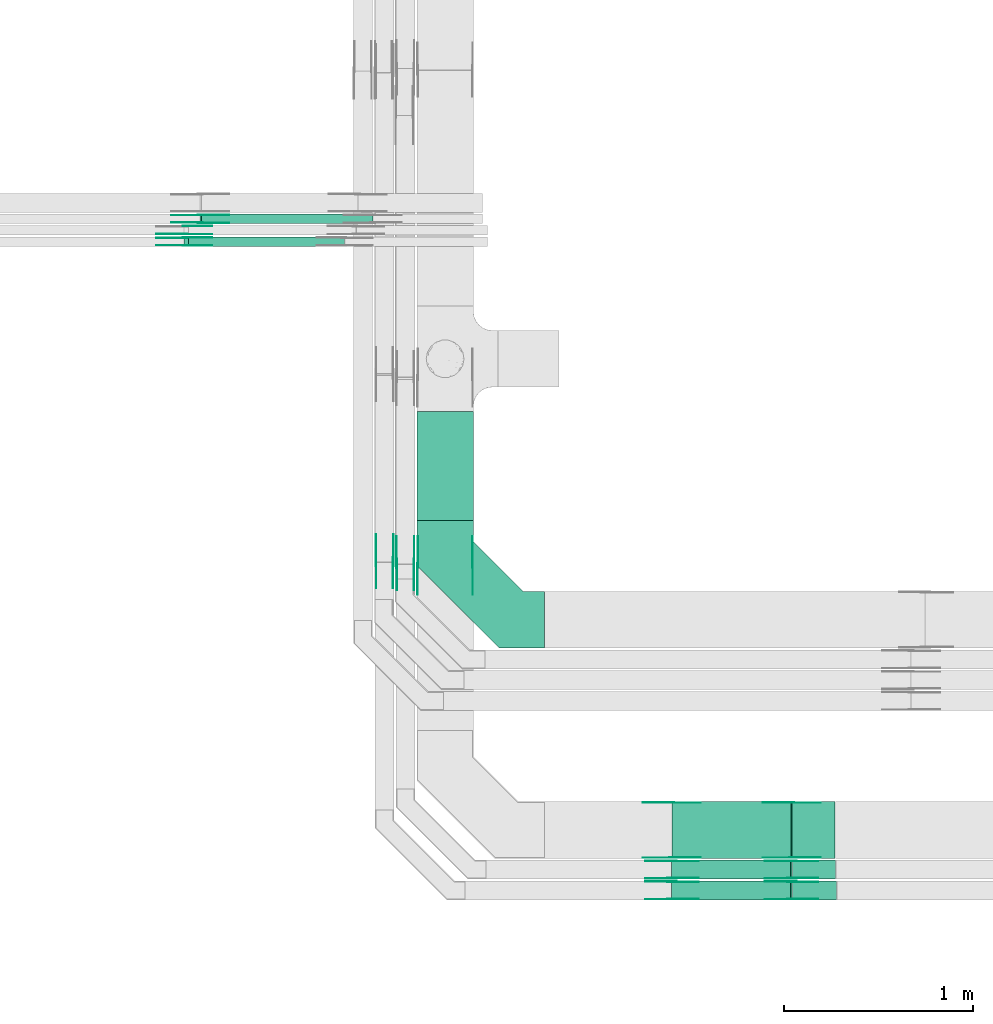
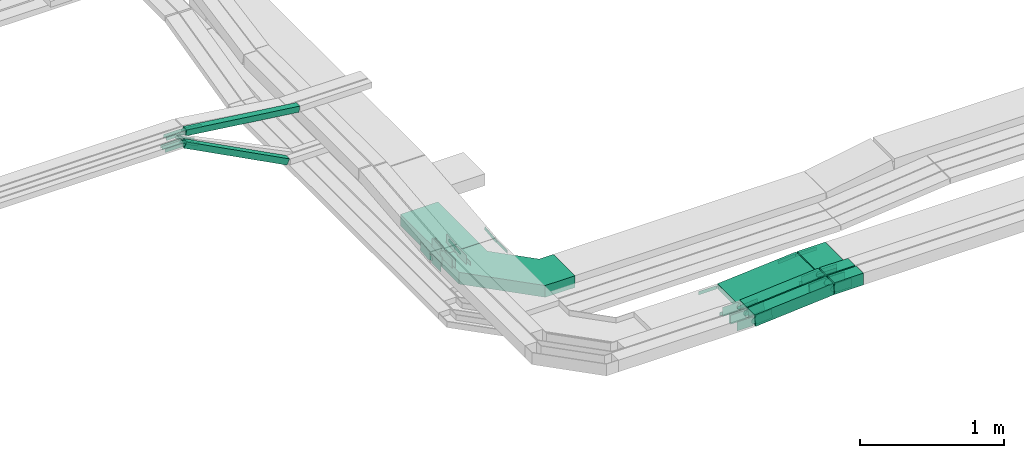
# One storey, part 5 of 32: 48 flow fittings, 9 flow segments.
"""IFC2X3 building model written with IfcOpenShell, lengths in millimetres."""

from ifc_helpers import new_model, entity, si_unit, converted_unit, derived_unit, direction, frame, frame_2d, origin, origin_2d_with_axis, place, context, subcontext, project, spatial, polyline, circle_curve, parameter, trimmed, segment, composite_curve, rectangle, outline, extrude, source, transform, mapped, material, type_object, type_shapes, element, save


model = new_model("IFC2X3")

# Units and contexts
model_context = context("Model", 3, precision=0.01, world=origin(), true_north=direction((6.12303176911189e-17, 1.0)))
body_context = subcontext(model_context, "Body", "Model", "MODEL_VIEW")
ifc_project = project(units=[si_unit("LENGTHUNIT", "METRE", prefix="MILLI"), si_unit("AREAUNIT", "SQUARE_METRE"), si_unit("VOLUMEUNIT", "CUBIC_METRE"), converted_unit("PLANEANGLEUNIT", "DEGREE", entity("IfcRatioMeasure", 0.0174532925199433), si_unit("PLANEANGLEUNIT", "RADIAN"), dimensions=[0, 0, 0, 0, 0, 0, 0]), si_unit("MASSUNIT", "GRAM", prefix="KILO"), derived_unit("MASSDENSITYUNIT", [(si_unit("MASSUNIT", "GRAM", prefix="KILO"), 1), (si_unit("LENGTHUNIT", "METRE"), -3)]), derived_unit("MOMENTOFINERTIAUNIT", [(si_unit("LENGTHUNIT", "METRE"), 4)]), si_unit("TIMEUNIT", "SECOND"), si_unit("FREQUENCYUNIT", "HERTZ"), si_unit("THERMODYNAMICTEMPERATUREUNIT", "DEGREE_CELSIUS"), derived_unit("THERMALTRANSMITTANCEUNIT", [(si_unit("MASSUNIT", "GRAM", prefix="KILO"), 1), (si_unit("THERMODYNAMICTEMPERATUREUNIT", "KELVIN"), -1), (si_unit("TIMEUNIT", "SECOND"), -3)]), derived_unit("VOLUMETRICFLOWRATEUNIT", [(si_unit("LENGTHUNIT", "METRE"), 3), (si_unit("TIMEUNIT", "SECOND"), -1)]), derived_unit("MASSFLOWRATEUNIT", [(si_unit("MASSUNIT", "GRAM", prefix="KILO"), 1), (si_unit("TIMEUNIT", "SECOND"), -1)]), derived_unit("ROTATIONALFREQUENCYUNIT", [(si_unit("TIMEUNIT", "SECOND"), -1)]), si_unit("ELECTRICCURRENTUNIT", "AMPERE"), si_unit("ELECTRICVOLTAGEUNIT", "VOLT"), si_unit("POWERUNIT", "WATT"), si_unit("FORCEUNIT", "NEWTON", prefix="KILO"), si_unit("ILLUMINANCEUNIT", "LUX"), si_unit("LUMINOUSFLUXUNIT", "LUMEN"), si_unit("LUMINOUSINTENSITYUNIT", "CANDELA"), derived_unit("USERDEFINED", [(si_unit("MASSUNIT", "GRAM", prefix="KILO"), -1), (si_unit("LENGTHUNIT", "METRE"), -2), (si_unit("TIMEUNIT", "SECOND"), 3), (si_unit("LUMINOUSFLUXUNIT", "LUMEN"), 1)]), derived_unit("LINEARVELOCITYUNIT", [(si_unit("LENGTHUNIT", "METRE"), 1), (si_unit("TIMEUNIT", "SECOND"), -1)]), si_unit("PRESSUREUNIT", "PASCAL"), derived_unit("USERDEFINED", [(si_unit("LENGTHUNIT", "METRE"), -2), (si_unit("MASSUNIT", "GRAM", prefix="KILO"), 1), (si_unit("TIMEUNIT", "SECOND"), -2)]), derived_unit("LINEARFORCEUNIT", [(si_unit("MASSUNIT", "GRAM", prefix="KILO"), 1), (si_unit("LENGTHUNIT", "METRE"), 1), (si_unit("TIMEUNIT", "SECOND"), -2), (si_unit("LENGTHUNIT", "METRE"), -1)]), derived_unit("PLANARFORCEUNIT", [(si_unit("MASSUNIT", "GRAM", prefix="KILO"), 1), (si_unit("LENGTHUNIT", "METRE"), 1), (si_unit("TIMEUNIT", "SECOND"), -2), (si_unit("LENGTHUNIT", "METRE"), -2)])], contexts=[model_context])

# Site, building, storey
site_placement = place(None, origin())
site = spatial("IfcSite", under=ifc_project, at=site_placement, CompositionType="ELEMENT")
building_placement = place(site_placement, origin())
building = spatial("IfcBuilding", under=site, at=building_placement, CompositionType="ELEMENT")
storey_placement = place(building_placement, frame((0.0, 0.0, 8100.0)))
storey = spatial("IfcBuildingStorey", under=building, at=storey_placement, CompositionType="ELEMENT", Elevation=8100.0)

# Flow segments
cable_carrier_segment_type = type_object("IfcCableCarrierSegmentType", PredefinedType="CABLETRAYSEGMENT")
flow_segment_1_placement = place(storey_placement, frame((18246.05, 10521.0, 2500.0)))
element("IfcFlowSegment", 1, at=flow_segment_1_placement, inside=storey, type_object=cable_carrier_segment_type, context=body_context, shape_type="SweptSolid", body=[
    extrude(rectangle(XDim=575.248008213486, YDim=300.000000000001, at=origin_2d_with_axis()), frame((150.0, 287.62, 0.0), z_axis=(0.0, 0.0, 1.0), x_axis=(0.0, -1.0, 0.0)), (0.0, 0.0, 1.0), 99.9999999999989),
])
flow_segment_2_placement = place(storey_placement, frame((19596.22, 8732.05, 2740.26)))
element("IfcFlowSegment", 2, at=flow_segment_2_placement, inside=storey, type_object=cable_carrier_segment_type, context=body_context, shape_type="SweptSolid", body=[
    extrude(rectangle(XDim=50.0000000000006, YDim=299.999999999999, at=frame_2d((0.0, 0.0), x_axis=(0.0, 1.0))), frame((1.96, 150.0, 24.92), z_axis=(0.996914404286907, 0.0, 0.0784963089914518), x_axis=(0.0, 1.0, 0.0)), (0.0, 0.0, 1.0), 632.69257167876),
])
flow_segment_3_placement = place(storey_placement, frame((19595.24, 8622.45, 2739.94)))
element("IfcFlowSegment", 3, at=flow_segment_3_placement, inside=storey, type_object=cable_carrier_segment_type, context=body_context, shape_type="SweptSolid", body=[
    extrude(rectangle(XDim=99.9999999999994, YDim=100.000000000001, at=frame_2d((0.0, 0.0), x_axis=(0.0, 1.0))), frame((3.94, 50.0, 49.84), z_axis=(0.996898073188744, 0.0, 0.0787034413006861), x_axis=(0.0, 1.0, 0.0)), (0.0, 0.0, 1.0), 630.726472303646),
])
flow_segment_4_placement = place(storey_placement, frame((19595.29, 8512.45, 2739.72)))
element("IfcFlowSegment", 4, at=flow_segment_4_placement, inside=storey, type_object=cable_carrier_segment_type, context=body_context, shape_type="SweptSolid", body=[
    extrude(rectangle(XDim=99.9999999999991, YDim=99.9999999999989, at=frame_2d((0.0, 0.0), x_axis=(0.0, 1.0))), frame((3.92, 50.0, 49.85), z_axis=(0.996914404286927, 0.0, 0.0784963089911935), x_axis=(0.0, 1.0, 0.0)), (0.0, 0.0, 1.0), 630.673844252395),
])
flow_segment_5_placement = place(storey_placement, frame((20233.2, 8732.05, 2790.02)))
element("IfcFlowSegment", 5, at=flow_segment_5_placement, inside=storey, type_object=cable_carrier_segment_type, context=body_context, shape_type="SweptSolid", body=[
    extrude(rectangle(XDim=226.881978270854, YDim=299.999999999999, at=origin_2d_with_axis()), frame((113.44, 150.0, 0.0), z_axis=(0.0, 0.0, 1.0), x_axis=(-1.0, 0.0, 0.0)), (0.0, 0.0, 1.0), 50.0000000000016),
])
flow_segment_6_placement = place(storey_placement, frame((20234.19, 8622.45, 2789.67)))
element("IfcFlowSegment", 6, at=flow_segment_6_placement, inside=storey, type_object=cable_carrier_segment_type, context=body_context, shape_type="SweptSolid", body=[
    extrude(rectangle(XDim=228.057615509405, YDim=99.9999999999989, at=origin_2d_with_axis()), frame((114.03, 50.0, 0.0), z_axis=(0.0, 0.0, 1.0), x_axis=(-1.0, 0.0, 0.0)), (0.0, 0.0, 1.0), 99.9999999999989),
])
flow_segment_7_placement = place(storey_placement, frame((20234.18, 8512.45, 2789.32)))
element("IfcFlowSegment", 7, at=flow_segment_7_placement, inside=storey, type_object=cable_carrier_segment_type, context=body_context, shape_type="SweptSolid", body=[
    extrude(rectangle(XDim=232.215307012604, YDim=99.9999999999989, at=origin_2d_with_axis()), frame((116.11, 50.0, 0.0), z_axis=(0.0, 0.0, 1.0), x_axis=(-1.0, 0.0, 0.0)), (0.0, 0.0, 1.0), 99.9999999999989),
])
flow_segment_8_placement = place(storey_placement, frame((17015.19, 11971.75, 2626.63)))
element("IfcFlowSegment", 8, at=flow_segment_8_placement, inside=storey, type_object=cable_carrier_segment_type, context=body_context, shape_type="SweptSolid", body=[
    extrude(rectangle(XDim=49.9999999999963, YDim=50.0000000000016, at=frame_2d((0.0, 0.0), x_axis=(0.0, 1.0))), frame((11.6, 25.0, 454.6), z_axis=(0.885831535280106, 0.0, -0.464006994670651), x_axis=(0.0, 1.0, 0.0)), (0.0, 0.0, 1.0), 931.990724329228),
])
flow_segment_9_placement = place(storey_placement, frame((17099.24, 12091.75, 2944.3)))
element("IfcFlowSegment", 9, at=flow_segment_9_placement, inside=storey, type_object=cable_carrier_segment_type, context=body_context, shape_type="SweptSolid", body=[
    extrude(rectangle(XDim=50.0000000000024, YDim=50.0000000000016, at=origin_2d_with_axis()), frame((3.16, 25.0, 140.34), z_axis=(0.992001694765703, 0.0, -0.126224552215377), x_axis=(0.126224552215377, 0.0, 0.992001694765703)), (0.0, 0.0, 1.0), 915.336723453825),
])

# Flow fittings
ifc_material_1 = material()
cable_carrier_fitting_type_1 = type_object("IfcCableCarrierFittingType", Name="470_DKC_G5_Sheet horizontal bend:-", PredefinedType="NOTDEFINED", material=ifc_material_1)
shared_shape_1 = source(origin(), body_context, "Body", "SweptSolid", [
    extrude(outline(polyline([(-307.0, -369.0), (-68.87, -369.0), (369.0, 68.87), (369.0, 307.0), (69.0, 307.0), (69.0, 193.13), (-193.13, -69.0), (-307.0, -69.0), (-307.0, -369.0)])), frame((-219.0, 219.0, -50.0)), (0.0, 0.0, 1.0), 100.0),
])
type_shapes(cable_carrier_fitting_type_1, [shared_shape_1])
flow_fitting_1_placement = place(storey_placement, frame((18396.05, 9995.0, 2550.0), z_axis=(0.0, 0.0, 1.0), x_axis=(0.0, -1.0, 0.0)))
element("IfcFlowFitting", 10, at=flow_fitting_1_placement, inside=storey, type_object=cable_carrier_fitting_type_1, material=ifc_material_1, Name="470_DKC_G5_Sheet horizontal bend:-", ObjectType="470_DKC_G5_Sheet horizontal bend:-", context=body_context, shape_type="MappedRepresentation", body=[
    mapped(shared_shape_1, transform((0.0, 0.0, 0.0), scale=1.0)),
])
ifc_material_2 = material(Name="G")
cable_carrier_fitting_type_2 = type_object("IfcCableCarrierFittingType", PredefinedType="NOTDEFINED", material=ifc_material_2)
shared_shape_2 = source(origin(), body_context, "Body", "SweptSolid", [
    extrude(outline(composite_curve([segment(trimmed(circle_curve(frame_2d((-44.59, 0.0), x_axis=(1.0, 0.0)), 12.5), [parameter(90.0000000000007)], [parameter(270.0)], True, "PARAMETER"), True, "CONTINUOUS"), segment(polyline([(-44.59, -12.5), (-33.09, -12.5)]), True, "CONTINUOUS"), segment(polyline([(-33.09, -12.5), (-31.23, -14.5)]), True, "CONTINUOUS"), segment(polyline([(-31.23, -14.5), (108.91, -14.5)]), True, "CONTINUOUS"), segment(polyline([(108.91, -14.5), (108.91, 14.5)]), True, "CONTINUOUS"), segment(polyline([(108.91, 14.5), (-31.23, 14.5)]), True, "CONTINUOUS"), segment(polyline([(-31.23, 14.5), (-33.09, 12.5)]), True, "CONTINUOUS"), segment(polyline([(-33.09, 12.5), (-44.59, 12.5)]), True, "CONTINUOUS")], self_intersect=False)), frame((44.59, 0.0, 0.0), z_axis=(0.0, 0.0, -1.0), x_axis=(1.0, 0.0, 0.0)), (0.0, 0.0, -1.0), 2.0),
])
type_shapes(cable_carrier_fitting_type_2, [shared_shape_2])
flow_fitting_2_placement = place(storey_placement, frame((20231.06, 8736.59, 2815.02), z_axis=(0.0, -1.0, 0.0), x_axis=(-0.996914404286911, 0.0, -0.0784963089914033)))
element("IfcFlowFitting", 11, at=flow_fitting_2_placement, inside=storey, type_object=cable_carrier_fitting_type_2, material=ifc_material_2, context=body_context, shape_type="MappedRepresentation", body=[
    mapped(shared_shape_2, transform((0.0, 0.0, 0.0), scale=1.0)),
])
cable_carrier_fitting_type_3 = type_object("IfcCableCarrierFittingType", PredefinedType="NOTDEFINED", material=ifc_material_2)
type_shapes(cable_carrier_fitting_type_3, [shared_shape_2])
flow_fitting_3_placement = place(storey_placement, frame((20231.06, 9025.51, 2815.02), z_axis=(0.0, 1.0, 0.0), x_axis=(1.0, 0.0, 0.0)))
element("IfcFlowFitting", 12, at=flow_fitting_3_placement, inside=storey, type_object=cable_carrier_fitting_type_3, material=ifc_material_2, context=body_context, shape_type="MappedRepresentation", body=[
    mapped(shared_shape_2, transform((0.0, 0.0, 0.0), scale=1.0)),
])
flow_fitting_4_placement = place(storey_placement, frame((18250.59, 10282.05, 2765.02), z_axis=(-1.0, 0.0, 0.0), x_axis=(0.0, -1.0, 0.0)))
element("IfcFlowFitting", 13, at=flow_fitting_4_placement, inside=storey, type_object=cable_carrier_fitting_type_2, material=ifc_material_2, context=body_context, shape_type="MappedRepresentation", body=[
    mapped(shared_shape_2, transform((0.0, 0.0, 0.0), scale=1.0)),
])
flow_fitting_5_placement = place(storey_placement, frame((18539.51, 10282.05, 2765.02), z_axis=(1.0, 0.0, 0.0), x_axis=(0.0, 0.99497485470274, 0.100125114278398)))
element("IfcFlowFitting", 14, at=flow_fitting_5_placement, inside=storey, type_object=cable_carrier_fitting_type_3, material=ifc_material_2, context=body_context, shape_type="MappedRepresentation", body=[
    mapped(shared_shape_2, transform((0.0, 0.0, 0.0), scale=1.0)),
])
flow_fitting_6_placement = place(storey_placement, frame((17099.58, 12137.21, 3085.0), z_axis=(0.0, 1.0, 0.0), x_axis=(0.992001694765699, 0.0, -0.126224552215409)))
element("IfcFlowFitting", 15, at=flow_fitting_6_placement, inside=storey, type_object=cable_carrier_fitting_type_2, material=ifc_material_2, context=body_context, shape_type="MappedRepresentation", body=[
    mapped(shared_shape_2, transform((0.0, 0.0, 0.0), scale=1.0)),
])
flow_fitting_7_placement = place(storey_placement, frame((17099.58, 12098.29, 3085.0), z_axis=(0.0, -1.0, 0.0), x_axis=(-1.0, 0.0, 0.0)))
element("IfcFlowFitting", 16, at=flow_fitting_7_placement, inside=storey, type_object=cable_carrier_fitting_type_3, material=ifc_material_2, context=body_context, shape_type="MappedRepresentation", body=[
    mapped(shared_shape_2, transform((0.0, 0.0, 0.0), scale=1.0)),
])
flow_fitting_8_placement = place(storey_placement, frame((17019.58, 12017.21, 3085.0), z_axis=(0.0, 1.0, 0.0), x_axis=(0.885831535280083, 0.0, -0.464006994670695)))
element("IfcFlowFitting", 17, at=flow_fitting_8_placement, inside=storey, type_object=cable_carrier_fitting_type_2, material=ifc_material_2, context=body_context, shape_type="MappedRepresentation", body=[
    mapped(shared_shape_2, transform((0.0, 0.0, 0.0), scale=1.0)),
])
flow_fitting_9_placement = place(storey_placement, frame((17019.58, 11978.29, 3085.0), z_axis=(0.0, -1.0, 0.0), x_axis=(-1.0, 0.0, 0.0)))
element("IfcFlowFitting", 18, at=flow_fitting_9_placement, inside=storey, type_object=cable_carrier_fitting_type_3, material=ifc_material_2, context=body_context, shape_type="MappedRepresentation", body=[
    mapped(shared_shape_2, transform((0.0, 0.0, 0.0), scale=1.0)),
])
flow_fitting_10_placement = place(storey_placement, frame((17019.58, 12077.21, 3085.0), z_axis=(0.0, 1.0, 0.0), x_axis=(0.898384360919165, 0.0, -0.439210132005016)))
element("IfcFlowFitting", 19, at=flow_fitting_10_placement, inside=storey, type_object=cable_carrier_fitting_type_2, material=ifc_material_2, context=body_context, shape_type="MappedRepresentation", body=[
    mapped(shared_shape_2, transform((0.0, 0.0, 0.0), scale=1.0)),
])
flow_fitting_11_placement = place(storey_placement, frame((17019.58, 12038.29, 3085.0), z_axis=(0.0, -1.0, 0.0), x_axis=(-1.0, 0.0, 0.0)))
element("IfcFlowFitting", 20, at=flow_fitting_11_placement, inside=storey, type_object=cable_carrier_fitting_type_3, material=ifc_material_2, context=body_context, shape_type="MappedRepresentation", body=[
    mapped(shared_shape_2, transform((0.0, 0.0, 0.0), scale=1.0)),
])
flow_fitting_12_placement = place(storey_placement, frame((19596.05, 9027.51, 2765.02), z_axis=(0.0, 1.0, 0.0), x_axis=(-1.0, 0.0, 0.0)))
element("IfcFlowFitting", 21, at=flow_fitting_12_placement, inside=storey, type_object=cable_carrier_fitting_type_2, material=ifc_material_2, context=body_context, shape_type="MappedRepresentation", body=[
    mapped(shared_shape_2, transform((0.0, 0.0, 0.0), scale=1.0)),
])
flow_fitting_13_placement = place(storey_placement, frame((19596.05, 8738.59, 2765.02), z_axis=(0.0, -1.0, 0.0), x_axis=(0.996914404286914, 0.0, 0.0784963089913655)))
element("IfcFlowFitting", 22, at=flow_fitting_13_placement, inside=storey, type_object=cable_carrier_fitting_type_3, material=ifc_material_2, context=body_context, shape_type="MappedRepresentation", body=[
    mapped(shared_shape_2, transform((0.0, 0.0, 0.0), scale=1.0)),
])
cable_carrier_fitting_type_4 = type_object("IfcCableCarrierFittingType", PredefinedType="NOTDEFINED", material=ifc_material_2)
shared_shape_3 = source(origin(), body_context, "Body", "SweptSolid", [
    extrude(outline(composite_curve([segment(trimmed(circle_curve(frame_2d((-44.59, 0.0), x_axis=(1.0, 0.0)), 12.5), [parameter(90.0000000000007)], [parameter(270.0)], True, "PARAMETER"), True, "CONTINUOUS"), segment(polyline([(-44.59, -12.5), (-33.09, -12.5)]), True, "CONTINUOUS"), segment(polyline([(-33.09, -12.5), (-31.23, -14.5)]), True, "CONTINUOUS"), segment(polyline([(-31.23, -14.5), (108.91, -14.5)]), True, "CONTINUOUS"), segment(polyline([(108.91, -14.5), (108.91, 14.5)]), True, "CONTINUOUS"), segment(polyline([(108.91, 14.5), (-31.23, 14.5)]), True, "CONTINUOUS"), segment(polyline([(-31.23, 14.5), (-33.09, 12.5)]), True, "CONTINUOUS"), segment(polyline([(-33.09, 12.5), (-44.59, 12.5)]), True, "CONTINUOUS")], self_intersect=False)), frame((44.59, 0.0, 0.0)), (0.0, 0.0, 1.0), 2.0),
])
type_shapes(cable_carrier_fitting_type_4, [shared_shape_3])
flow_fitting_14_placement = place(storey_placement, frame((20231.06, 9027.51, 2815.02), z_axis=(0.0, 1.0, 0.0), x_axis=(-0.996914404286911, 0.0, -0.0784963089914033)))
element("IfcFlowFitting", 23, at=flow_fitting_14_placement, inside=storey, type_object=cable_carrier_fitting_type_4, material=ifc_material_2, context=body_context, shape_type="MappedRepresentation", body=[
    mapped(shared_shape_3, transform((0.0, 0.0, 0.0), scale=1.0)),
])
cable_carrier_fitting_type_5 = type_object("IfcCableCarrierFittingType", PredefinedType="NOTDEFINED", material=ifc_material_2)
type_shapes(cable_carrier_fitting_type_5, [shared_shape_3])
flow_fitting_15_placement = place(storey_placement, frame((20231.06, 8738.59, 2815.02), z_axis=(0.0, -1.0, 0.0), x_axis=(1.0, 0.0, 0.0)))
element("IfcFlowFitting", 24, at=flow_fitting_15_placement, inside=storey, type_object=cable_carrier_fitting_type_5, material=ifc_material_2, context=body_context, shape_type="MappedRepresentation", body=[
    mapped(shared_shape_3, transform((0.0, 0.0, 0.0), scale=1.0)),
])
flow_fitting_16_placement = place(storey_placement, frame((18541.51, 10282.05, 2765.02), z_axis=(1.0, 0.0, 0.0), x_axis=(0.0, -1.0, 0.0)))
element("IfcFlowFitting", 25, at=flow_fitting_16_placement, inside=storey, type_object=cable_carrier_fitting_type_4, material=ifc_material_2, context=body_context, shape_type="MappedRepresentation", body=[
    mapped(shared_shape_3, transform((0.0, 0.0, 0.0), scale=1.0)),
])
flow_fitting_17_placement = place(storey_placement, frame((18252.59, 10282.05, 2765.02), z_axis=(-1.0, 0.0, 0.0), x_axis=(0.0, 0.99497485470274, 0.100125114278398)))
element("IfcFlowFitting", 26, at=flow_fitting_17_placement, inside=storey, type_object=cable_carrier_fitting_type_5, material=ifc_material_2, context=body_context, shape_type="MappedRepresentation", body=[
    mapped(shared_shape_3, transform((0.0, 0.0, 0.0), scale=1.0)),
])
flow_fitting_18_placement = place(storey_placement, frame((17099.58, 12096.29, 3085.0), z_axis=(0.0, -1.0, 0.0), x_axis=(0.992001694765699, 0.0, -0.126224552215409)))
element("IfcFlowFitting", 27, at=flow_fitting_18_placement, inside=storey, type_object=cable_carrier_fitting_type_4, material=ifc_material_2, context=body_context, shape_type="MappedRepresentation", body=[
    mapped(shared_shape_3, transform((0.0, 0.0, 0.0), scale=1.0)),
])
flow_fitting_19_placement = place(storey_placement, frame((17099.58, 12135.21, 3085.0), z_axis=(0.0, 1.0, 0.0), x_axis=(-1.0, 0.0, 0.0)))
element("IfcFlowFitting", 28, at=flow_fitting_19_placement, inside=storey, type_object=cable_carrier_fitting_type_5, material=ifc_material_2, context=body_context, shape_type="MappedRepresentation", body=[
    mapped(shared_shape_3, transform((0.0, 0.0, 0.0), scale=1.0)),
])
flow_fitting_20_placement = place(storey_placement, frame((17019.58, 11976.29, 3085.0), z_axis=(0.0, -1.0, 0.0), x_axis=(0.885831535280083, 0.0, -0.464006994670695)))
element("IfcFlowFitting", 29, at=flow_fitting_20_placement, inside=storey, type_object=cable_carrier_fitting_type_4, material=ifc_material_2, context=body_context, shape_type="MappedRepresentation", body=[
    mapped(shared_shape_3, transform((0.0, 0.0, 0.0), scale=1.0)),
])
flow_fitting_21_placement = place(storey_placement, frame((17019.58, 12015.21, 3085.0), z_axis=(0.0, 1.0, 0.0), x_axis=(-1.0, 0.0, 0.0)))
element("IfcFlowFitting", 30, at=flow_fitting_21_placement, inside=storey, type_object=cable_carrier_fitting_type_5, material=ifc_material_2, context=body_context, shape_type="MappedRepresentation", body=[
    mapped(shared_shape_3, transform((0.0, 0.0, 0.0), scale=1.0)),
])
for number, where, z_axis, x_axis in (
    (31, (17019.58, 12036.29, 3085.0), (0.0, -1.0, 0.0), (0.898384360919165, 0.0, -0.439210132005016)),
    (32, (19596.05, 8736.59, 2765.02), (0.0, -1.0, 0.0), (-1.0, 0.0, 0.0)),
):
    element("IfcFlowFitting", number, at=place(storey_placement, frame(where, z_axis=z_axis, x_axis=x_axis)), inside=storey, type_object=cable_carrier_fitting_type_4, material=ifc_material_2, context=body_context, shape_type="MappedRepresentation", body=[
        mapped(shared_shape_3, transform((0.0, 0.0, 0.0), scale=1.0)),
    ])
flow_fitting_22_placement = place(storey_placement, frame((19596.05, 9025.51, 2765.02), z_axis=(0.0, 1.0, 0.0), x_axis=(0.996914404286914, 0.0, 0.0784963089913655)))
element("IfcFlowFitting", 33, at=flow_fitting_22_placement, inside=storey, type_object=cable_carrier_fitting_type_5, material=ifc_material_2, context=body_context, shape_type="MappedRepresentation", body=[
    mapped(shared_shape_3, transform((0.0, 0.0, 0.0), scale=1.0)),
])
cable_carrier_fitting_type_6 = type_object("IfcCableCarrierFittingType", PredefinedType="NOTDEFINED", material=ifc_material_2)
shared_shape_4 = source(origin(), body_context, "Body", "SweptSolid", [
    extrude(outline(composite_curve([segment(trimmed(circle_curve(frame_2d((-41.47, 0.0), x_axis=(1.0, 0.0)), 25.0), [parameter(90.0000000000007)], [parameter(270.0)], True, "PARAMETER"), True, "CONTINUOUS"), segment(polyline([(-41.47, -25.0), (-29.97, -25.0)]), True, "CONTINUOUS"), segment(polyline([(-29.97, -25.0), (-28.1, -38.5)]), True, "CONTINUOUS"), segment(polyline([(-28.1, -38.5), (99.53, -38.5)]), True, "CONTINUOUS"), segment(polyline([(99.53, -38.5), (99.53, 38.5)]), True, "CONTINUOUS"), segment(polyline([(99.53, 38.5), (-28.1, 38.5)]), True, "CONTINUOUS"), segment(polyline([(-28.1, 38.5), (-29.97, 25.0)]), True, "CONTINUOUS"), segment(polyline([(-29.97, 25.0), (-41.47, 25.0)]), True, "CONTINUOUS")], self_intersect=False)), frame((41.47, 0.0, 0.0), z_axis=(0.0, 0.0, -1.0), x_axis=(1.0, 0.0, 0.0)), (0.0, 0.0, -1.0), 2.0),
])
type_shapes(cable_carrier_fitting_type_6, [shared_shape_4])
flow_fitting_23_placement = place(storey_placement, frame((18231.51, 10292.45, 2789.54), z_axis=(1.0, 0.0, 0.0), x_axis=(0.0, 0.994821450765371, 0.101637990422292)))
element("IfcFlowFitting", 34, at=flow_fitting_23_placement, inside=storey, type_object=cable_carrier_fitting_type_6, material=ifc_material_2, context=body_context, shape_type="MappedRepresentation", body=[
    mapped(shared_shape_4, transform((0.0, 0.0, 0.0), scale=1.0)),
])
cable_carrier_fitting_type_7 = type_object("IfcCableCarrierFittingType", PredefinedType="NOTDEFINED", material=ifc_material_2)
type_shapes(cable_carrier_fitting_type_7, [shared_shape_4])
flow_fitting_24_placement = place(storey_placement, frame((18142.59, 10292.45, 2789.54), z_axis=(-1.0, 0.0, 0.0), x_axis=(0.0, -1.0, 0.0)))
element("IfcFlowFitting", 35, at=flow_fitting_24_placement, inside=storey, type_object=cable_carrier_fitting_type_7, material=ifc_material_2, context=body_context, shape_type="MappedRepresentation", body=[
    mapped(shared_shape_4, transform((0.0, 0.0, 0.0), scale=1.0)),
])
flow_fitting_25_placement = place(storey_placement, frame((18121.51, 10302.45, 2789.32), z_axis=(1.0, 0.0, 0.0), x_axis=(0.0, 0.994903033239732, 0.100836275468608)))
element("IfcFlowFitting", 36, at=flow_fitting_25_placement, inside=storey, type_object=cable_carrier_fitting_type_6, material=ifc_material_2, context=body_context, shape_type="MappedRepresentation", body=[
    mapped(shared_shape_4, transform((0.0, 0.0, 0.0), scale=1.0)),
])
flow_fitting_26_placement = place(storey_placement, frame((18032.59, 10302.45, 2789.32), z_axis=(-1.0, 0.0, 0.0), x_axis=(0.0, -1.0, 0.0)))
element("IfcFlowFitting", 37, at=flow_fitting_26_placement, inside=storey, type_object=cable_carrier_fitting_type_7, material=ifc_material_2, context=body_context, shape_type="MappedRepresentation", body=[
    mapped(shared_shape_4, transform((0.0, 0.0, 0.0), scale=1.0)),
])
flow_fitting_27_placement = place(storey_placement, frame((20231.06, 8626.99, 2839.67), z_axis=(0.0, -1.0, 0.0), x_axis=(-0.99689807318874, 0.0, -0.0787034413007328)))
element("IfcFlowFitting", 38, at=flow_fitting_27_placement, inside=storey, type_object=cable_carrier_fitting_type_6, material=ifc_material_2, context=body_context, shape_type="MappedRepresentation", body=[
    mapped(shared_shape_4, transform((0.0, 0.0, 0.0), scale=1.0)),
])
flow_fitting_28_placement = place(storey_placement, frame((20231.06, 8715.91, 2839.67), z_axis=(0.0, 1.0, 0.0), x_axis=(1.0, 0.0, 0.0)))
element("IfcFlowFitting", 39, at=flow_fitting_28_placement, inside=storey, type_object=cable_carrier_fitting_type_7, material=ifc_material_2, context=body_context, shape_type="MappedRepresentation", body=[
    mapped(shared_shape_4, transform((0.0, 0.0, 0.0), scale=1.0)),
])
flow_fitting_29_placement = place(storey_placement, frame((20231.06, 8516.99, 2839.32), z_axis=(0.0, -1.0, 0.0), x_axis=(-0.996914404286923, 0.0, -0.0784963089912431)))
element("IfcFlowFitting", 40, at=flow_fitting_29_placement, inside=storey, type_object=cable_carrier_fitting_type_6, material=ifc_material_2, context=body_context, shape_type="MappedRepresentation", body=[
    mapped(shared_shape_4, transform((0.0, 0.0, 0.0), scale=1.0)),
])
flow_fitting_30_placement = place(storey_placement, frame((20231.06, 8605.91, 2839.32), z_axis=(0.0, 1.0, 0.0), x_axis=(1.0, 0.0, 0.0)))
element("IfcFlowFitting", 41, at=flow_fitting_30_placement, inside=storey, type_object=cable_carrier_fitting_type_7, material=ifc_material_2, context=body_context, shape_type="MappedRepresentation", body=[
    mapped(shared_shape_4, transform((0.0, 0.0, 0.0), scale=1.0)),
])
flow_fitting_31_placement = place(storey_placement, frame((19596.11, 8607.91, 2789.32), z_axis=(0.0, 1.0, 0.0), x_axis=(-1.0, 0.0, 0.0)))
element("IfcFlowFitting", 42, at=flow_fitting_31_placement, inside=storey, type_object=cable_carrier_fitting_type_6, material=ifc_material_2, context=body_context, shape_type="MappedRepresentation", body=[
    mapped(shared_shape_4, transform((0.0, 0.0, 0.0), scale=1.0)),
])
flow_fitting_32_placement = place(storey_placement, frame((19596.11, 8518.99, 2789.32), z_axis=(0.0, -1.0, 0.0), x_axis=(0.996914404286925, 0.0, 0.0784963089912197)))
element("IfcFlowFitting", 43, at=flow_fitting_32_placement, inside=storey, type_object=cable_carrier_fitting_type_7, material=ifc_material_2, context=body_context, shape_type="MappedRepresentation", body=[
    mapped(shared_shape_4, transform((0.0, 0.0, 0.0), scale=1.0)),
])
flow_fitting_33_placement = place(storey_placement, frame((19596.05, 8717.91, 2789.54), z_axis=(0.0, 1.0, 0.0), x_axis=(-1.0, 0.0, 0.0)))
element("IfcFlowFitting", 44, at=flow_fitting_33_placement, inside=storey, type_object=cable_carrier_fitting_type_6, material=ifc_material_2, context=body_context, shape_type="MappedRepresentation", body=[
    mapped(shared_shape_4, transform((0.0, 0.0, 0.0), scale=1.0)),
])
flow_fitting_34_placement = place(storey_placement, frame((19596.05, 8628.99, 2789.54), z_axis=(0.0, -1.0, 0.0), x_axis=(0.996898073188743, 0.0, 0.0787034413006984)))
element("IfcFlowFitting", 45, at=flow_fitting_34_placement, inside=storey, type_object=cable_carrier_fitting_type_7, material=ifc_material_2, context=body_context, shape_type="MappedRepresentation", body=[
    mapped(shared_shape_4, transform((0.0, 0.0, 0.0), scale=1.0)),
])
cable_carrier_fitting_type_8 = type_object("IfcCableCarrierFittingType", PredefinedType="NOTDEFINED", material=ifc_material_2)
shared_shape_5 = source(origin(), body_context, "Body", "SweptSolid", [
    extrude(outline(composite_curve([segment(trimmed(circle_curve(frame_2d((-41.47, 0.0), x_axis=(1.0, 0.0)), 25.0), [parameter(90.0000000000007)], [parameter(270.0)], True, "PARAMETER"), True, "CONTINUOUS"), segment(polyline([(-41.47, -25.0), (-29.97, -25.0)]), True, "CONTINUOUS"), segment(polyline([(-29.97, -25.0), (-28.1, -38.5)]), True, "CONTINUOUS"), segment(polyline([(-28.1, -38.5), (99.53, -38.5)]), True, "CONTINUOUS"), segment(polyline([(99.53, -38.5), (99.53, 38.5)]), True, "CONTINUOUS"), segment(polyline([(99.53, 38.5), (-28.1, 38.5)]), True, "CONTINUOUS"), segment(polyline([(-28.1, 38.5), (-29.97, 25.0)]), True, "CONTINUOUS"), segment(polyline([(-29.97, 25.0), (-41.47, 25.0)]), True, "CONTINUOUS")], self_intersect=False)), frame((41.47, 0.0, 0.0)), (0.0, 0.0, 1.0), 2.0),
])
type_shapes(cable_carrier_fitting_type_8, [shared_shape_5])
flow_fitting_35_placement = place(storey_placement, frame((18140.59, 10292.45, 2789.54), z_axis=(-1.0, 0.0, 0.0), x_axis=(0.0, 0.994821450765371, 0.101637990422292)))
element("IfcFlowFitting", 46, at=flow_fitting_35_placement, inside=storey, type_object=cable_carrier_fitting_type_8, material=ifc_material_2, context=body_context, shape_type="MappedRepresentation", body=[
    mapped(shared_shape_5, transform((0.0, 0.0, 0.0), scale=1.0)),
])
cable_carrier_fitting_type_9 = type_object("IfcCableCarrierFittingType", PredefinedType="NOTDEFINED", material=ifc_material_2)
type_shapes(cable_carrier_fitting_type_9, [shared_shape_5])
flow_fitting_36_placement = place(storey_placement, frame((18229.51, 10292.45, 2789.54), z_axis=(1.0, 0.0, 0.0), x_axis=(0.0, -1.0, 0.0)))
element("IfcFlowFitting", 47, at=flow_fitting_36_placement, inside=storey, type_object=cable_carrier_fitting_type_9, material=ifc_material_2, context=body_context, shape_type="MappedRepresentation", body=[
    mapped(shared_shape_5, transform((0.0, 0.0, 0.0), scale=1.0)),
])
flow_fitting_37_placement = place(storey_placement, frame((18030.59, 10302.45, 2789.32), z_axis=(-1.0, 0.0, 0.0), x_axis=(0.0, 0.994903033239732, 0.100836275468608)))
element("IfcFlowFitting", 48, at=flow_fitting_37_placement, inside=storey, type_object=cable_carrier_fitting_type_8, material=ifc_material_2, context=body_context, shape_type="MappedRepresentation", body=[
    mapped(shared_shape_5, transform((0.0, 0.0, 0.0), scale=1.0)),
])
flow_fitting_38_placement = place(storey_placement, frame((18119.51, 10302.45, 2789.32), z_axis=(1.0, 0.0, 0.0), x_axis=(0.0, -1.0, 0.0)))
element("IfcFlowFitting", 49, at=flow_fitting_38_placement, inside=storey, type_object=cable_carrier_fitting_type_9, material=ifc_material_2, context=body_context, shape_type="MappedRepresentation", body=[
    mapped(shared_shape_5, transform((0.0, 0.0, 0.0), scale=1.0)),
])
flow_fitting_39_placement = place(storey_placement, frame((20231.06, 8717.91, 2839.67), z_axis=(0.0, 1.0, 0.0), x_axis=(-0.99689807318874, 0.0, -0.0787034413007328)))
element("IfcFlowFitting", 50, at=flow_fitting_39_placement, inside=storey, type_object=cable_carrier_fitting_type_8, material=ifc_material_2, context=body_context, shape_type="MappedRepresentation", body=[
    mapped(shared_shape_5, transform((0.0, 0.0, 0.0), scale=1.0)),
])
flow_fitting_40_placement = place(storey_placement, frame((20231.06, 8628.99, 2839.67), z_axis=(0.0, -1.0, 0.0), x_axis=(1.0, 0.0, 0.0)))
element("IfcFlowFitting", 51, at=flow_fitting_40_placement, inside=storey, type_object=cable_carrier_fitting_type_9, material=ifc_material_2, context=body_context, shape_type="MappedRepresentation", body=[
    mapped(shared_shape_5, transform((0.0, 0.0, 0.0), scale=1.0)),
])
flow_fitting_41_placement = place(storey_placement, frame((20231.06, 8607.91, 2839.32), z_axis=(0.0, 1.0, 0.0), x_axis=(-0.996914404286923, 0.0, -0.0784963089912431)))
element("IfcFlowFitting", 52, at=flow_fitting_41_placement, inside=storey, type_object=cable_carrier_fitting_type_8, material=ifc_material_2, context=body_context, shape_type="MappedRepresentation", body=[
    mapped(shared_shape_5, transform((0.0, 0.0, 0.0), scale=1.0)),
])
flow_fitting_42_placement = place(storey_placement, frame((20231.06, 8518.99, 2839.32), z_axis=(0.0, -1.0, 0.0), x_axis=(1.0, 0.0, 0.0)))
element("IfcFlowFitting", 53, at=flow_fitting_42_placement, inside=storey, type_object=cable_carrier_fitting_type_9, material=ifc_material_2, context=body_context, shape_type="MappedRepresentation", body=[
    mapped(shared_shape_5, transform((0.0, 0.0, 0.0), scale=1.0)),
])
flow_fitting_43_placement = place(storey_placement, frame((19596.11, 8516.99, 2789.32), z_axis=(0.0, -1.0, 0.0), x_axis=(-1.0, 0.0, 0.0)))
element("IfcFlowFitting", 54, at=flow_fitting_43_placement, inside=storey, type_object=cable_carrier_fitting_type_8, material=ifc_material_2, context=body_context, shape_type="MappedRepresentation", body=[
    mapped(shared_shape_5, transform((0.0, 0.0, 0.0), scale=1.0)),
])
flow_fitting_44_placement = place(storey_placement, frame((19596.11, 8605.91, 2789.32), z_axis=(0.0, 1.0, 0.0), x_axis=(0.996914404286925, 0.0, 0.0784963089912197)))
element("IfcFlowFitting", 55, at=flow_fitting_44_placement, inside=storey, type_object=cable_carrier_fitting_type_9, material=ifc_material_2, context=body_context, shape_type="MappedRepresentation", body=[
    mapped(shared_shape_5, transform((0.0, 0.0, 0.0), scale=1.0)),
])
flow_fitting_45_placement = place(storey_placement, frame((19596.05, 8626.99, 2789.54), z_axis=(0.0, -1.0, 0.0), x_axis=(-1.0, 0.0, 0.0)))
element("IfcFlowFitting", 56, at=flow_fitting_45_placement, inside=storey, type_object=cable_carrier_fitting_type_8, material=ifc_material_2, context=body_context, shape_type="MappedRepresentation", body=[
    mapped(shared_shape_5, transform((0.0, 0.0, 0.0), scale=1.0)),
])
flow_fitting_46_placement = place(storey_placement, frame((19596.05, 8715.91, 2789.54), z_axis=(0.0, 1.0, 0.0), x_axis=(0.996898073188743, 0.0, 0.0787034413006984)))
element("IfcFlowFitting", 57, at=flow_fitting_46_placement, inside=storey, type_object=cable_carrier_fitting_type_9, material=ifc_material_2, context=body_context, shape_type="MappedRepresentation", body=[
    mapped(shared_shape_5, transform((0.0, 0.0, 0.0), scale=1.0)),
])

save(model, "model.ifc")
